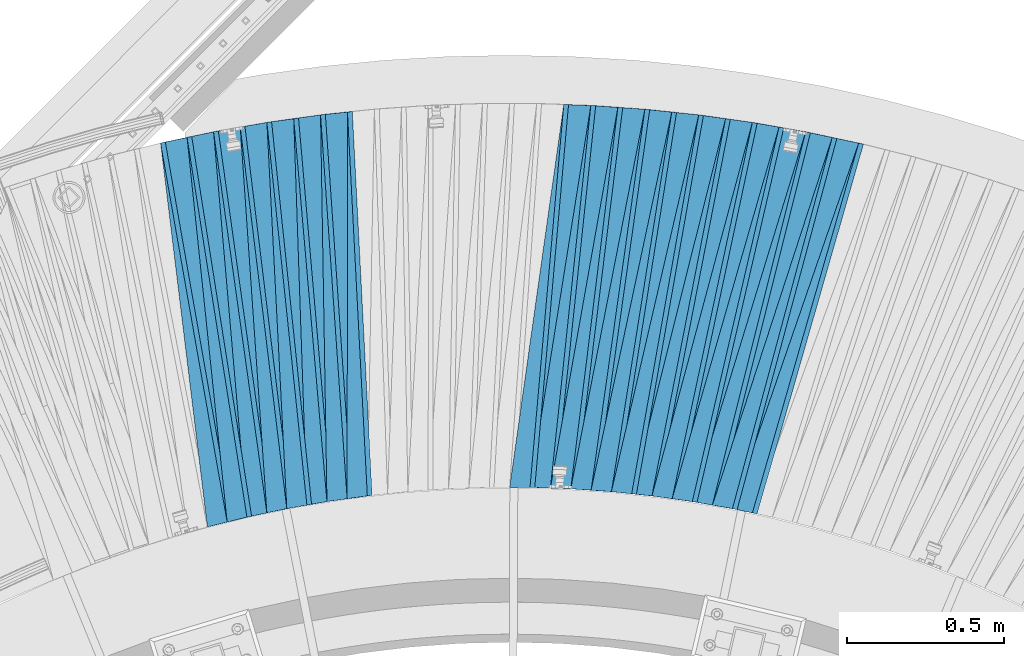
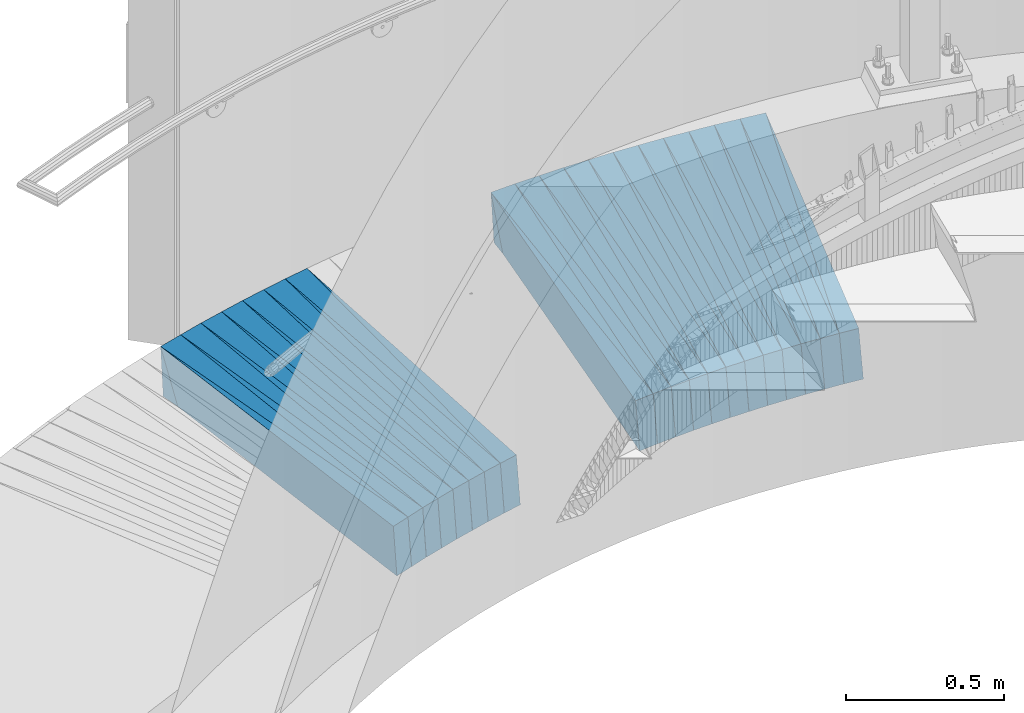
# One storey, part 838 of 975: 38 plates.
"""IFC2X3 building model written with IfcOpenShell, lengths in millimetres."""

from ifc_helpers import new_model, si_unit, frame, origin_with_axes, place, context, subcontext, project, spatial, faceted_brep, material, type_object, element, save


model = new_model("IFC2X3")

# Units and contexts
model_context = context("Model", 3, precision=1e-05, world=origin_with_axes())
body_context = subcontext(model_context, "Body", "Model", "MODEL_VIEW")
ifc_project = project(units=[si_unit("LENGTHUNIT", "METRE", prefix="MILLI"), si_unit("AREAUNIT", "SQUARE_METRE"), si_unit("VOLUMEUNIT", "CUBIC_METRE"), si_unit("MASSUNIT", "GRAM", prefix="KILO"), si_unit("TIMEUNIT", "SECOND"), si_unit("PLANEANGLEUNIT", "RADIAN"), si_unit("SOLIDANGLEUNIT", "STERADIAN"), si_unit("THERMODYNAMICTEMPERATUREUNIT", "DEGREE_CELSIUS"), si_unit("LUMINOUSINTENSITYUNIT", "LUMEN")], contexts=[model_context])

# Site, building, storey
site_placement = place(None, origin_with_axes())
site = spatial("IfcSite", under=ifc_project, at=site_placement, CompositionType="ELEMENT")
building_placement = place(site_placement, origin_with_axes())
building = spatial("IfcBuilding", under=site, at=building_placement, Name="Undefined", CompositionType="ELEMENT")
storey_placement = place(building_placement, origin_with_axes())
storey = spatial("IfcBuildingStorey", under=building, at=storey_placement, Name="Undefined", CompositionType="ELEMENT", Elevation=0.0)

# Plates
ifc_material = material(Name="STEEL/A36")
plate_type_1 = type_object("IfcPlateType", PredefinedType="NOTDEFINED")
plate_1_placement = place(storey_placement, frame((35764.605502556, 8221.70274465771, 73.7905738008885), z_axis=(0.964055581401103, -0.259311554563337, 0.057916782018052), x_axis=(-0.259515912954683, -0.965730145831356, -0.00409589499928474)))
element("IfcPlate", 1, at=plate_1_placement, inside=storey, type_object=plate_type_1, material=ifc_material, Name="SLAB", context=body_context, shape_type="Brep", body=[
    faceted_brep([(-6.82121026329696e-12, -100.000000000011, -1.09139364212751e-10), (-4.55919837962938, -99.9999999999691, 86.0083389287502), (-4.559198379382, 99.9999999999982, 86.0083389282008), (5.91171556152403e-12, 100.000000000011, 1.09139364212751e-10), (1220.73437500095, -100.00000000007, -6.584741640836e-10), (1220.7343750012, 99.9999999998965, -1.21508492156863e-09)], [[[0, 1, 2, 3]], [[1, 4, 5, 2]], [[4, 0, 3, 5]], [[5, 3, 2]], [[4, 1, 0]]]),
])
plate_2_placement = place(storey_placement, frame((35680.4185467574, 8239.69587528962, 68.7903290060016), z_axis=(0.968478990564453, -0.242277277368658, 0.0578806159788259), x_axis=(-0.242456660088825, -0.970153952355419, -0.00400957700146893)))
element("IfcPlate", 2, at=plate_2_placement, inside=storey, type_object=plate_type_1, material=ifc_material, Name="SLAB", context=body_context, shape_type="Brep", body=[
    faceted_brep([(-6.82121026329696e-12, -100.000000000011, -1.09139364212751e-10), (-3.06914281841091, -100.000000000004, 86.1720962523905), (-3.06914281867284, 100.000000000015, 86.1720962527033), (5.91171556152403e-12, 100.000000000011, 1.09139364212751e-10), (1222.07409668038, -100.000000000044, -5.56610757485032e-10), (1222.07409668012, 99.9999999999743, -2.47382558882236e-10)], [[[0, 1, 2, 3]], [[1, 4, 5, 2]], [[4, 0, 3, 5]], [[5, 3, 2]], [[4, 1, 0]]]),
])
plate_3_placement = place(storey_placement, frame((35595.6267236072, 8254.72910454201, 63.8838515331064), z_axis=(0.972598820152964, -0.225458207081955, 0.0567462060093355), x_axis=(-0.225593408988377, -0.974212932949807, -0.00409574099978898)))
element("IfcPlate", 3, at=plate_3_placement, inside=storey, type_object=plate_type_1, material=ifc_material, Name="SLAB", context=body_context, shape_type="Brep", body=[
    faceted_brep([(-6.82121026329696e-12, -100.000000000011, -1.09139364212751e-10), (-4.61205816275833, -99.9999999999795, 86.0165023807131), (-4.61205816267102, 99.999999999987, 86.0165023801528), (5.91171556152403e-12, 100.000000000011, 1.09139364212751e-10), (1220.7803955086, -100.000000000214, -3.77258402295411e-09), (1220.78039550869, 99.9999999997531, -4.33647073805332e-09)], [[[0, 1, 2, 3]], [[1, 4, 5, 2]], [[4, 0, 3, 5]], [[5, 3, 2]], [[4, 1, 0]]]),
])
plate_4_placement = place(storey_placement, frame((35511.0556919054, 8269.6944571652, 58.8906398262733), z_axis=(0.976331071088854, -0.2083777056512, 0.0579341990022646), x_axis=(-0.208499042945997, -0.978014351746696, -0.00400959699896152)))
element("IfcPlate", 4, at=plate_4_placement, inside=storey, type_object=plate_type_1, material=ifc_material, Name="SLAB", context=body_context, shape_type="Brep", body=[
    faceted_brep([(-6.82121026329696e-12, -100.000000000011, -1.09139364212751e-10), (-3.10750317586462, -99.9999999999727, 86.0897369389422), (-3.10750317581915, 99.9999999999966, 86.0897369383965), (5.91171556152403e-12, 100.000000000011, 1.09139364212751e-10), (1222.06799316404, -99.9999999997672, 4.69299266114831e-09), (1222.06799316408, 100.000000000202, 4.16184775531292e-09)], [[[0, 1, 2, 3]], [[1, 4, 5, 2]], [[4, 0, 3, 5]], [[5, 3, 2]], [[4, 1, 0]]]),
])
plate_5_placement = place(storey_placement, frame((35425.8579234587, 8281.82470681886, 53.9840768629625), z_axis=(0.979861523169143, -0.191433444205892, 0.0567858420041172), x_axis=(-0.19151260201159, -0.981481609059398, -0.00409565000024787)))
element("IfcPlate", 5, at=plate_5_placement, inside=storey, type_object=plate_type_1, material=ifc_material, Name="SLAB", context=body_context, shape_type="Brep", body=[
    faceted_brep([(-6.82121026329696e-12, -100.000000000011, -1.09139364212751e-10), (-4.54001188280381, -99.9999999999804, 85.961669922217), (-4.54001188273469, 99.9999999999905, 85.9616699217149), (5.91171556152403e-12, 100.000000000011, 1.09139364212751e-10), (1220.80737304752, -99.9999999998954, 1.78260961547494e-09), (1220.80737304759, 100.000000000075, 1.28056854009628e-09)], [[[0, 1, 2, 3]], [[1, 4, 5, 2]], [[4, 0, 3, 5]], [[5, 3, 2]], [[4, 1, 0]]]),
])
plate_6_placement = place(storey_placement, frame((35340.7792414724, 8293.90386042257, 48.9905059479369), z_axis=(0.983000901638346, -0.174230280495049, 0.057905411982096), x_axis=(-0.174287989057401, -0.984686223324289, -0.00409126700134739)))
element("IfcPlate", 6, at=plate_6_placement, inside=storey, type_object=plate_type_1, material=ifc_material, Name="SLAB", context=body_context, shape_type="Brep", body=[
    faceted_brep([(-6.82121026329696e-12, -100.000000000011, -1.09139364212751e-10), (-3.05355834965485, -100.00000000002, 86.1319656368723), (-3.05355834966576, 100.000000000004, 86.131965637258), (5.91171556152403e-12, 100.000000000011, 1.09139364212751e-10), (1222.11523437546, -100.000000000117, -2.35013430938125e-09), (1222.11523437545, 99.9999999999063, -1.96450855582952e-09)], [[[0, 1, 2, 3]], [[1, 4, 5, 2]], [[4, 0, 3, 5]], [[5, 3, 2]], [[4, 1, 0]]]),
])
plate_7_placement = place(storey_placement, frame((35255.2900291314, 8302.99648943306, 43.9906100897005), z_axis=(0.985885321670632, -0.157080835764449, 0.0579287799797034), x_axis=(-0.157113782975789, -0.987572350847801, -0.00401385599938141)))
element("IfcPlate", 7, at=plate_7_placement, inside=storey, type_object=plate_type_1, material=ifc_material, Name="SLAB", context=body_context, shape_type="Brep", body=[
    faceted_brep([(-6.82121026329696e-12, -100.000000000011, -1.09139364212751e-10), (-4.56514644626259, -99.9999999999941, 85.9965667725555), (-4.5651464461971, 100.000000000007, 85.9965667725774), (5.91171556152403e-12, 100.000000000011, 1.09139364212751e-10), (1220.77136230519, -99.9999999998824, 1.90630089491606e-09), (1220.77136230525, 100.000000000118, 1.92812876775861e-09)], [[[0, 1, 2, 3]], [[1, 4, 5, 2]], [[4, 0, 3, 5]], [[5, 3, 2]], [[4, 1, 0]]]),
])
plate_8_placement = place(storey_placement, frame((35169.6864097936, 8312.01339526982, 39.0841267151234), z_axis=(0.988553321968879, -0.139771264818067, 0.0568007319975048), x_axis=(-0.139770274969739, -0.990175838785613, -0.00400980299913182)))
element("IfcPlate", 8, at=plate_8_placement, inside=storey, type_object=plate_type_1, material=ifc_material, Name="SLAB", context=body_context, shape_type="Brep", body=[
    faceted_brep([(-6.82121026329696e-12, -100.000000000011, -1.09139364212751e-10), (-3.15744161615476, -100.000000000003, 86.0435943603006), (-3.15744161608018, 100.000000000025, 86.0435943607881), (5.91171556152403e-12, 100.000000000011, 1.09139364212751e-10), (1222.00512695307, -99.9999999998477, 2.05909600481391e-09), (1222.00512695315, 100.00000000018, 2.55386112257838e-09)], [[[0, 1, 2, 3]], [[1, 4, 5, 2]], [[4, 0, 3, 5]], [[5, 3, 2]], [[4, 1, 0]]]),
])
plate_9_placement = place(storey_placement, frame((35083.8875538046, 8318.12138796366, 34.1838202332682), z_axis=(0.990834619860875, -0.122585688774441, 0.0567406819914285), x_axis=(-0.12255144400627, -0.992453710050773, -0.00409597100020955)))
element("IfcPlate", 9, at=plate_9_placement, inside=storey, type_object=plate_type_1, material=ifc_material, Name="SLAB", context=body_context, shape_type="Brep", body=[
    faceted_brep([(-6.82121026329696e-12, -100.000000000011, -1.09139364212751e-10), (-4.58026170729863, -99.9999999999757, 86.027153015566), (-4.58026170745325, 100.000000000013, 86.0271530153477), (5.91171556152403e-12, 100.000000000011, 1.09139364212751e-10), (1220.71179199231, -100.000000000141, -1.84809323400259e-09), (1220.71179199215, 99.9999999998465, -2.05909600481391e-09)], [[[0, 1, 2, 3]], [[1, 4, 5, 2]], [[4, 0, 3, 5]], [[5, 3, 2]], [[4, 1, 0]]]),
])
plate_10_placement = place(storey_placement, frame((34998.2095757124, 8324.20800457314, 29.1906252965995), z_axis=(0.992761712832039, -0.105208186985022, 0.0579259779902053), x_axis=(-0.1051481829612, -0.994448148633038, -0.00409136899849024)))
element("IfcPlate", 10, at=plate_10_placement, inside=storey, type_object=plate_type_1, material=ifc_material, Name="SLAB", context=body_context, shape_type="Brep", body=[
    faceted_brep([(-6.82121026329696e-12, -100.000000000011, -1.09139364212751e-10), (-3.07548213005975, -99.9999999999691, 86.0998306279726), (-3.07548212996699, 99.9999999999923, 86.0998306273177), (5.91171556152403e-12, 100.000000000011, 1.09139364212751e-10), (1222.08483886739, -99.9999999998463, 3.08500602841377e-09), (1222.0848388674, 100.000000000158, 3.09955794364214e-09)], [[[0, 1, 2, 3]], [[1, 4, 5, 2]], [[4, 0, 3, 5]], [[5, 3, 2]], [[4, 1, 0]]]),
])
plate_11_placement = place(storey_placement, frame((34912.2067349827, 8327.31002952668, 24.1903049663771), z_axis=(0.994446331117044, -0.0879062493161221, 0.0578704230071204), x_axis=(-0.0878165689614517, -0.996128241562713, -0.00409592199820195)))
element("IfcPlate", 11, at=plate_11_placement, inside=storey, type_object=plate_type_1, material=ifc_material, Name="SLAB", context=body_context, shape_type="Brep", body=[
    faceted_brep([(-6.82121026329696e-12, -100.000000000011, -1.09139364212751e-10), (-4.58431959140762, -100.000000000004, 86.0754547118559), (-4.58431959155314, 100.000000000022, 86.0754547122851), (5.91171556152403e-12, 100.000000000011, 1.09139364212751e-10), (1220.7263183595, -100.000000000236, -4.8748916015029e-09), (1220.72631835935, 99.9999999997897, -4.43833414465189e-09)], [[[0, 1, 2, 3]], [[1, 4, 5, 2]], [[4, 0, 3, 5]], [[5, 3, 2]], [[4, 1, 0]]]),
])
plate_12_placement = place(storey_placement, frame((34139.759102008, 8295.31905065966, -20.4092313566496), z_axis=(0.99594667004959, 0.0687891565701411, 0.0579506889993781), x_axis=(0.069141298985726, -0.997598487794038, -0.00409120099915534)))
element("IfcPlate", 12, at=plate_12_placement, inside=storey, type_object=plate_type_1, material=ifc_material, Name="SLAB", context=body_context, shape_type="Brep", body=[
    faceted_brep([(-6.82121026329696e-12, -100.000000000011, -1.09139364212751e-10), (-3.08726119992662, -99.9999999999977, 86.0622940063986), (-3.087261199973, 100.000000000032, 86.0622940069079), (5.91171556152403e-12, 100.000000000011, 1.09139364212751e-10), (1222.13500976625, -100.000000000171, -3.47063178196549e-09), (1222.1350097662, 99.9999999998595, -2.95403879135847e-09)], [[[0, 1, 2, 3]], [[1, 4, 5, 2]], [[4, 0, 3, 5]], [[5, 3, 2]], [[4, 1, 0]]]),
])
plate_13_placement = place(storey_placement, frame((34054.5368614062, 8283.41892436918, -25.4096521035713), z_axis=(0.994602079277499, 0.0861211889418626, 0.0578778430154009), x_axis=(0.0865016370427408, -0.99624328949228, -0.00409572100202385)))
element("IfcPlate", 13, at=plate_13_placement, inside=storey, type_object=plate_type_1, material=ifc_material, Name="SLAB", context=body_context, shape_type="Brep", body=[
    faceted_brep([(-6.82121026329696e-12, -100.000000000011, -1.09139364212751e-10), (-4.60545873652791, -99.999999999987, 86.0629425050938), (-4.60545873638694, 99.9999999999895, 86.0629425047009), (5.91171556152403e-12, 100.000000000011, 1.09139364212751e-10), (1220.78613281197, -99.9999999998649, 2.62662069872022e-09), (1220.78613281211, 100.000000000112, 2.2409949451685e-09)], [[[0, 1, 2, 3]], [[1, 4, 5, 2]], [[4, 0, 3, 5]], [[5, 3, 2]], [[4, 1, 0]]]),
])
plate_14_placement = place(storey_placement, frame((33969.3226987477, 8271.5194156429, -30.4094995051612), z_axis=(0.992932359180917, 0.103597318001857, 0.0579044540103788), x_axis=(0.104006596044437, -0.994568191424915, -0.00409152600174805)))
element("IfcPlate", 14, at=plate_14_placement, inside=storey, type_object=plate_type_1, material=ifc_material, Name="SLAB", context=body_context, shape_type="Brep", body=[
    faceted_brep([(-6.82121026329696e-12, -100.000000000011, -1.09139364212751e-10), (-3.09391403193695, -99.9999999999914, 86.1305236817861), (-3.09391403215795, 99.9999999999695, 86.1305236810949), (5.91171556152403e-12, 100.000000000011, 1.09139364212751e-10), (1222.03784179759, -99.9999999997447, 5.17320586368442e-09), (1222.03784179737, 100.000000000216, 4.48926584795117e-09)], [[[0, 1, 2, 3]], [[1, 4, 5, 2]], [[4, 0, 3, 5]], [[5, 3, 2]], [[4, 1, 0]]]),
])
plate_15_placement = place(storey_placement, frame((33884.7124940008, 8256.71114013125, -35.4091145866803), z_axis=(0.990991434238703, 0.120725880859667, 0.0579761930120975), x_axis=(0.121159712948324, -0.992624909576633, -0.00401408099828794)))
element("IfcPlate", 15, at=plate_15_placement, inside=storey, type_object=plate_type_1, material=ifc_material, Name="SLAB", context=body_context, shape_type="Brep", body=[
    faceted_brep([(-6.82121026329696e-12, -100.000000000011, -1.09139364212751e-10), (-4.56007003787408, -100.000000000015, 85.9265747067693), (-4.56007003778313, 99.9999999999768, 85.9265747066311), (5.91171556152403e-12, 100.000000000011, 1.09139364212751e-10), (1220.70275878989, -99.9999999997904, 3.18686943501234e-09), (1220.70275878998, 100.000000000202, 3.06317815557122e-09)], [[[0, 1, 2, 3]], [[1, 4, 5, 2]], [[4, 0, 3, 5]], [[5, 3, 2]], [[4, 1, 0]]]),
])
plate_16_placement = place(storey_placement, frame((33799.8737275223, 8241.89392777915, -40.3160031597552), z_axis=(0.988791594099933, 0.138084942108144, 0.0567779200068544), x_axis=(0.138532769005874, -0.990349734042003, -0.00400951300017006)))
element("IfcPlate", 16, at=plate_16_placement, inside=storey, type_object=plate_type_1, material=ifc_material, Name="SLAB", context=body_context, shape_type="Brep", body=[
    faceted_brep([(-6.82121026329696e-12, -100.000000000011, -1.09139364212751e-10), (-3.04213213912999, -99.9999999999995, 86.0863265991284), (-3.04213213918047, 99.9999999999973, 86.0863265990847), (5.91171556152403e-12, 100.000000000011, 1.09139364212751e-10), (1222.09350585966, -99.999999999872, 3.60887497663498e-09), (1222.09350585961, 100.000000000125, 3.56521923094988e-09)], [[[0, 1, 2, 3]], [[1, 4, 5, 2]], [[4, 0, 3, 5]], [[5, 3, 2]], [[4, 1, 0]]]),
])
plate_17_placement = place(storey_placement, frame((33715.6425197186, 8224.09809821937, -45.216449938061), z_axis=(0.986236292747657, 0.155318581026175, 0.0566931499863439), x_axis=(0.15579721704757, -0.987780569301605, -0.00409561600125054)))
element("IfcPlate", 17, at=plate_17_placement, inside=storey, type_object=plate_type_1, material=ifc_material, Name="SLAB", context=body_context, shape_type="Brep", body=[
    faceted_brep([(-6.82121026329696e-12, -100.000000000011, -1.09139364212751e-10), (-4.58321523664108, -99.9999999999948, 86.0990982056683), (-4.58321523675841, 99.9999999999702, 86.0990982050353), (5.91171556152403e-12, 100.000000000011, 1.09139364212751e-10), (1220.81774902334, -99.9999999999127, 3.78349795937538e-10), (1220.81774902322, 100.000000000053, -2.5465851649642e-10)], [[[0, 1, 2, 3]], [[1, 4, 5, 2]], [[4, 0, 3, 5]], [[5, 3, 2]], [[4, 1, 0]]]),
])
plate_18_placement = place(storey_placement, frame((33631.6440143375, 8206.30793033107, -50.2092933695438), z_axis=(0.983297056879705, 0.172537504394019, 0.0579457289987202), x_axis=(0.173055720005732, -0.984903875032618, -0.00400932900013278)))
element("IfcPlate", 18, at=plate_18_placement, inside=storey, type_object=plate_type_1, material=ifc_material, Name="SLAB", context=body_context, shape_type="Brep", body=[
    faceted_brep([(-6.82121026329696e-12, -100.000000000011, -1.09139364212751e-10), (-3.09583997723848, -99.9999999999879, 86.073432922567), (-3.09583997711343, 100.000000000011, 86.073432922567), (5.91171556152403e-12, 100.000000000011, 1.09139364212751e-10), (1222.14978027348, -99.9999999999643, 2.69210431724787e-10), (1222.1497802736, 100.000000000035, 2.7648638933897e-10)], [[[0, 1, 2, 3]], [[1, 4, 5, 2]], [[4, 0, 3, 5]], [[5, 3, 2]], [[4, 1, 0]]]),
])
plate_type_2 = type_object("IfcPlateType", PredefinedType="NOTDEFINED")
plate_19_placement = place(storey_placement, frame((35850.5119113249, 8203.17787494596, 78.9190200785627), z_axis=(0.942252558940146, -0.3260250351283, 0.0766015119977239), x_axis=(-0.326383799059595, -0.945202272172581, -0.00814127700148648)))
element("IfcPlate", 19, at=plate_19_placement, inside=storey, type_object=plate_type_2, material=ifc_material, Name="SLAB", context=body_context, shape_type="Brep", body=[
    faceted_brep([(-6.82121026329696e-12, -100.000000000011, -1.09139364212751e-10), (1220.36791992194, -100.000000000029, 64.4289321896067), (1220.36791992196, 99.9999999999741, 64.4289321896467), (5.91171556152403e-12, 100.000000000011, 1.09139364212751e-10), (1228.30847167972, -100.000000000028, -1.93540472537279e-09), (1228.30847167975, 99.999999999975, -1.89902493730187e-09)], [[[0, 1, 2, 3]], [[1, 4, 5, 2]], [[4, 0, 3, 5]], [[5, 3, 2]], [[4, 1, 0]]]),
])
plate_20_placement = place(storey_placement, frame((35682.2607297798, 8239.2349549028, 68.9185700473539), z_axis=(0.953078958781384, -0.29288282840706, 0.0765515979746576), x_axis=(-0.293143726972705, -0.956034415910989, -0.00805921399924965)))
element("IfcPlate", 20, at=plate_20_placement, inside=storey, type_object=plate_type_2, material=ifc_material, Name="SLAB", context=body_context, shape_type="Brep", body=[
    faceted_brep([(-6.82121026329696e-12, -100.000000000011, -1.09139364212751e-10), (1220.37243652325, -99.9999999999977, 64.4694824219368), (1220.3724365233, 99.9999999999923, 64.4694824218095), (5.91171556152403e-12, 100.000000000011, 1.09139364212751e-10), (1228.40771484352, -99.9999999999945, -3.27418092638254e-10), (1228.40771484356, 99.999999999995, -4.54747350886464e-10)], [[[0, 1, 2, 3]], [[1, 4, 5, 2]], [[4, 0, 3, 5]], [[5, 3, 2]], [[4, 1, 0]]]),
])
plate_21_placement = place(storey_placement, frame((35512.9129287261, 8269.29799392248, 59.018991973222), z_axis=(0.962711705406642, -0.259456387254315, 0.0766064970219533), x_axis=(-0.259614670981735, -0.965678655932064, -0.00805953399943301)))
element("IfcPlate", 21, at=plate_21_placement, inside=storey, type_object=plate_type_2, material=ifc_material, Name="SLAB", context=body_context, shape_type="Brep", body=[
    faceted_brep([(-6.82121026329696e-12, -100.000000000011, -1.09139364212751e-10), (1220.36840820335, -100.000000000219, 64.4279632539692), (1220.36840820337, 99.9999999997931, 64.4279632541329), (5.91171556152403e-12, 100.000000000011, 1.09139364212751e-10), (1228.35888671898, -100.000000000207, -2.08092387765646e-09), (1228.35888671901, 99.9999999998045, -1.91357685253024e-09)], [[[0, 1, 2, 3]], [[1, 4, 5, 2]], [[4, 0, 3, 5]], [[5, 3, 2]], [[4, 1, 0]]]),
])
plate_22_placement = place(storey_placement, frame((35427.8337766105, 8281.43860353971, 54.1189733335936), z_axis=(0.967073963605498, -0.242695492112916, 0.0765953459710329), x_axis=(-0.242795784909989, -0.970043253640377, -0.00814204499698151)))
element("IfcPlate", 22, at=plate_22_placement, inside=storey, type_object=plate_type_2, material=ifc_material, Name="SLAB", context=body_context, shape_type="Brep", body=[
    faceted_brep([(-6.82121026329696e-12, -100.000000000011, -1.09139364212751e-10), (1219.11218261705, -99.9999999997185, 64.3128662146046), (1219.1121826169, 100.000000000332, 64.3128662152558), (5.91171556152403e-12, 100.000000000011, 1.09139364212751e-10), (1228.19262695305, -99.9999999997171, 4.58021531812847e-09), (1228.19262695289, 100.000000000333, 5.23141352459788e-09)], [[[0, 1, 2, 3]], [[1, 4, 5, 2]], [[4, 0, 3, 5]], [[5, 3, 2]], [[4, 1, 0]]]),
])
plate_23_placement = place(storey_placement, frame((35342.508214564, 8293.59734715231, 49.1078660835137), z_axis=(0.971292333788656, -0.22570892054748, 0.0751444309891155), x_axis=(-0.225749904975231, -0.974151950893104, -0.00805958899911561)))
element("IfcPlate", 23, at=plate_23_placement, inside=storey, type_object=plate_type_2, material=ifc_material, Name="SLAB", context=body_context, shape_type="Brep", body=[
    faceted_brep([(-6.82121026329696e-12, -100.000000000011, -1.09139364212751e-10), (1220.41943359372, -99.999999999899, 64.3571243299193), (1220.41943359373, 100.000000000155, 64.3571243306396), (5.91171556152403e-12, 100.000000000011, 1.09139364212751e-10), (1228.35046386717, -99.9999999998877, 2.3283064365387e-10), (1228.35046386718, 100.000000000166, 9.53150447458029e-10)], [[[0, 1, 2, 3]], [[1, 4, 5, 2]], [[4, 0, 3, 5]], [[5, 3, 2]], [[4, 1, 0]]]),
])
plate_24_placement = place(storey_placement, frame((35171.6757641942, 8311.73203879611, 39.2187392565894), z_axis=(0.978462847858353, -0.191694925611359, 0.0765735649932661), x_axis=(-0.191645688012599, -0.981431082064528, -0.00805986500052993)))
element("IfcPlate", 24, at=plate_24_placement, inside=storey, type_object=plate_type_2, material=ifc_material, Name="SLAB", context=body_context, shape_type="Brep", body=[
    faceted_brep([(-6.82121026329696e-12, -100.000000000011, -1.09139364212751e-10), (1220.30419921816, -100.000000000085, 64.4541931140193), (1220.30419921823, 99.9999999999177, 64.4541931140629), (5.91171556152403e-12, 100.000000000011, 1.09139364212751e-10), (1228.30834960875, -100.00000000009, -1.80443748831749e-09), (1228.30834960883, 99.9999999999122, -1.76078174263239e-09)], [[[0, 1, 2, 3]], [[1, 4, 5, 2]], [[4, 0, 3, 5]], [[5, 3, 2]], [[4, 1, 0]]]),
])
plate_25_placement = place(storey_placement, frame((35000.0967918447, 8324.00793178634, 29.3188622100358), z_axis=(0.984553814007914, -0.15744567773302, 0.0765809760035732), x_axis=(-0.157286689056187, -0.987519427352785, -0.00814113300290837)))
element("IfcPlate", 25, at=plate_25_placement, inside=storey, type_object=plate_type_2, material=ifc_material, Name="SLAB", context=body_context, shape_type="Brep", body=[
    faceted_brep([(-6.82121026329696e-12, -100.000000000011, -1.09139364212751e-10), (1220.38439941511, -100.000000000022, 64.4456634519738), (1220.38439941509, 99.9999999999645, 64.4456634517992), (5.91171556152403e-12, 100.000000000011, 1.09139364212751e-10), (1228.3303222667, -100.000000000018, -2.40106601268053e-10), (1228.33032226668, 99.9999999999686, -4.07453626394272e-10)], [[[0, 1, 2, 3]], [[1, 4, 5, 2]], [[4, 0, 3, 5]], [[5, 3, 2]], [[4, 1, 0]]]),
])
plate_26_placement = place(storey_placement, frame((34141.6514219088, 8295.44967728745, -20.2810219608469), z_axis=(0.996934856286814, 0.0159351166474935, 0.0765961120280901), x_axis=(0.0166068320036651, -0.999828957220828, -0.00814060400179798)))
element("IfcPlate", 26, at=plate_26_placement, inside=storey, type_object=plate_type_2, material=ifc_material, Name="SLAB", context=body_context, shape_type="Brep", body=[
    faceted_brep([(-6.82121026329696e-12, -100.000000000011, -1.09139364212751e-10), (1220.43542480526, -100.000000000065, 64.4299240104301), (1220.4354248053, 99.9999999999745, 64.429924010954), (5.91171556152403e-12, 100.000000000011, 1.09139364212751e-10), (1228.41015625058, -100.000000000072, -1.5352270565927e-09), (1228.41015625062, 99.9999999999682, -1.00408215075731e-09)], [[[0, 1, 2, 3]], [[1, 4, 5, 2]], [[4, 0, 3, 5]], [[5, 3, 2]], [[4, 1, 0]]]),
])
plate_27_placement = place(storey_placement, frame((33971.0556864283, 8271.7001635962, -30.2931651609586), z_axis=(0.995888756903831, 0.050788508731999, 0.0750074079896188), x_axis=(0.0515358099916105, -0.998638620837467, -0.00806010299868819)))
element("IfcPlate", 27, at=plate_27_placement, inside=storey, type_object=plate_type_2, material=ifc_material, Name="SLAB", context=body_context, shape_type="Brep", body=[
    faceted_brep([(-6.82121026329696e-12, -100.000000000011, -1.09139364212751e-10), (1220.33593749919, -99.9999999997199, 64.4740676916263), (1220.33593749903, 100.000000000275, 64.4740676915535), (5.91171556152403e-12, 100.000000000011, 1.09139364212751e-10), (1228.27209472574, -99.999999999704, 3.71801434084773e-09), (1228.27209472558, 100.000000000291, 3.63797880709171e-09)], [[[0, 1, 2, 3]], [[1, 4, 5, 2]], [[4, 0, 3, 5]], [[5, 3, 2]], [[4, 1, 0]]]),
])
plate_28_placement = place(storey_placement, frame((33801.8697804081, 8242.17259423601, -40.1809540116154), z_axis=(0.993394772198545, 0.085423575803843, 0.0766135710268467), x_axis=(0.0862895700130673, -0.99623750215085, -0.00805912000122031)))
element("IfcPlate", 28, at=plate_28_placement, inside=storey, type_object=plate_type_2, material=ifc_material, Name="SLAB", context=body_context, shape_type="Brep", body=[
    faceted_brep([(-6.82121026329696e-12, -100.000000000011, -1.09139364212751e-10), (1220.39453125059, -100.000000000116, 64.4181747421972), (1220.39453125067, 99.999999999935, 64.4181747428738), (5.91171556152403e-12, 100.000000000011, 1.09139364212751e-10), (1228.42187500054, -100.000000000133, -1.71712599694729e-09), (1228.42187500062, 99.9999999999181, -1.04773789644241e-09)], [[[0, 1, 2, 3]], [[1, 4, 5, 2]], [[4, 0, 3, 5]], [[5, 3, 2]], [[4, 1, 0]]]),
])
plate_29_placement = place(storey_placement, frame((33633.5156159512, 8206.63626321406, -50.0808342030895), z_axis=(0.989801267511988, 0.120089248387306, 0.0766291279699453), x_axis=(0.121054357045533, -0.992613161373355, -0.00805943600303142)))
element("IfcPlate", 29, at=plate_29_placement, inside=storey, type_object=plate_type_2, material=ifc_material, Name="SLAB", context=body_context, shape_type="Brep", body=[
    faceted_brep([(-6.82121026329696e-12, -100.000000000011, -1.09139364212751e-10), (1220.4509277354, -99.9999999997035, 64.4160537759599), (1220.45092773547, 100.000000000255, 64.4160537754215), (5.91171556152403e-12, 100.000000000011, 1.09139364212751e-10), (1228.37377929787, -99.9999999996971, 4.79485606774688e-09), (1228.37377929794, 100.000000000261, 4.2564352042973e-09)], [[[0, 1, 2, 3]], [[1, 4, 5, 2]], [[4, 0, 3, 5]], [[5, 3, 2]], [[4, 1, 0]]]),
])
plate_type_3 = type_object("IfcPlateType", PredefinedType="NOTDEFINED")
plate_30_placement = place(storey_placement, frame((35766.3013381842, 8221.24653318741, 73.9079688859877), z_axis=(0.947917965809429, -0.309520295864185, 0.0751579439837355), x_axis=(-0.309810530907454, -0.950764144715987, -0.00806077299759208)))
element("IfcPlate", 30, at=plate_30_placement, inside=storey, type_object=plate_type_3, material=ifc_material, Name="SLAB", context=body_context, shape_type="Brep", body=[
    faceted_brep([(-6.82121026329696e-12, -100.000000000011, -1.09139364212751e-10), (1219.04418945479, -100.000000000311, 64.217277522861), (1219.04418945476, 99.999999999694, 64.2172775229155), (5.91171556152403e-12, 100.000000000011, 1.09139364212751e-10), (1228.17004394692, -100.000000000308, -1.70621206052601e-09), (1228.1700439469, 99.9999999996971, -1.66255631484091e-09)], [[[0, 1, 2, 3]], [[1, 4, 5, 2]], [[4, 0, 3, 5]], [[5, 3, 2]], [[4, 1, 0]]]),
])
plate_31_placement = place(storey_placement, frame((35597.4455454985, 8254.30740957835, 64.0075057639823), z_axis=(0.95815267972445, -0.276231712386705, 0.075096493984497), x_axis=(-0.276421592975933, -0.961002668916325, -0.00806059999929816)))
element("IfcPlate", 31, at=plate_31_placement, inside=storey, type_object=plate_type_3, material=ifc_material, Name="SLAB", context=body_context, shape_type="Brep", body=[
    faceted_brep([(-6.82121026329696e-12, -100.000000000011, -1.09139364212751e-10), (1219.08728027489, -100.000000000174, 64.2716445901569), (1219.08728027511, 99.9999999997835, 64.2716445896076), (5.91171556152403e-12, 100.000000000011, 1.09139364212751e-10), (1228.19641113429, -100.000000000185, -2.16823536902666e-09), (1228.19641113451, 99.9999999997726, -2.7212081477046e-09)], [[[0, 1, 2, 3]], [[1, 4, 5, 2]], [[4, 0, 3, 5]], [[5, 3, 2]], [[4, 1, 0]]]),
])
plate_32_placement = place(storey_placement, frame((35257.0260513541, 8302.71982630221, 44.1081627425714), z_axis=(0.97508797015605, -0.208685314902629, 0.0751923520109962), x_axis=(-0.208682709083387, -0.977950846390766, -0.00797928400318833)))
element("IfcPlate", 32, at=plate_32_placement, inside=storey, type_object=plate_type_3, material=ifc_material, Name="SLAB", context=body_context, shape_type="Brep", body=[
    faceted_brep([(-6.82121026329696e-12, -100.000000000011, -1.09139364212751e-10), (1219.0820312497, -99.9999999999086, 64.2006988536668), (1219.08203124992, 100.000000000053, 64.200698853183), (5.91171556152403e-12, 100.000000000011, 1.09139364212751e-10), (1228.1802978512, -99.9999999998954, 2.71029421128333e-09), (1228.18029785141, 100.000000000066, 2.22644302994013e-09)], [[[0, 1, 2, 3]], [[1, 4, 5, 2]], [[4, 0, 3, 5]], [[5, 3, 2]], [[4, 1, 0]]]),
])
plate_33_placement = place(storey_placement, frame((35085.8928084871, 8317.87321383893, 34.3191905459753), z_axis=(0.981654845575646, -0.17459263161284, 0.0766236069651959), x_axis=(-0.174485542962386, -0.984626071787759, -0.00814211599824492)))
element("IfcPlate", 33, at=plate_33_placement, inside=storey, type_object=plate_type_3, material=ifc_material, Name="SLAB", context=body_context, shape_type="Brep", body=[
    faceted_brep([(-6.82121026329696e-12, -100.000000000011, -1.09139364212751e-10), (1219.01818847685, -100.000000000136, 64.2802886945137), (1219.01818847687, 99.9999999998181, 64.2802886939171), (5.91171556152403e-12, 100.000000000011, 1.09139364212751e-10), (1228.18200683628, -100.00000000015, -2.64844857156277e-09), (1228.18200683629, 99.999999999804, -3.25235305353999e-09)], [[[0, 1, 2, 3]], [[1, 4, 5, 2]], [[4, 0, 3, 5]], [[5, 3, 2]], [[4, 1, 0]]]),
])
plate_34_placement = place(storey_placement, frame((34913.9578578065, 8327.15517128327, 24.3077564124241), z_axis=(0.987271896269856, -0.14017748644017, 0.0751297220215664), x_axis=(-0.13996888104867, -0.990123089344283, -0.00806103500280296)))
element("IfcPlate", 34, at=plate_34_placement, inside=storey, type_object=plate_type_3, material=ifc_material, Name="SLAB", context=body_context, shape_type="Brep", body=[
    faceted_brep([(-6.82121026329696e-12, -100.000000000011, -1.09139364212751e-10), (1219.03466796939, -100.000000000013, 64.244628906119), (1219.03466796921, 100.000000000014, 64.2446289064537), (5.91171556152403e-12, 100.000000000011, 1.09139364212751e-10), (1228.13012695376, -100.000000000026, -1.35332811623812e-09), (1228.13012695357, 100.0, -1.02591002359986e-09)], [[[0, 1, 2, 3]], [[1, 4, 5, 2]], [[4, 0, 3, 5]], [[5, 3, 2]], [[4, 1, 0]]]),
])
plate_35_placement = place(storey_placement, frame((34227.1701069625, 8304.31644865006, -15.2807528382524), z_axis=(0.997058486855251, -0.00143573373887738, 0.0766310149909827), x_axis=(-0.000814172000133446, -0.999966524166804, -0.00814172400135812)))
element("IfcPlate", 35, at=plate_35_placement, inside=storey, type_object=plate_type_3, material=ifc_material, Name="SLAB", context=body_context, shape_type="Brep", body=[
    faceted_brep([(-6.82121026329696e-12, -100.000000000011, -1.09139364212751e-10), (1219.1485595702, -100.00000000022, 64.2816848726216), (1219.14855957006, 99.9999999997576, 64.2816848722941), (5.91171556152403e-12, 100.000000000011, 1.09139364212751e-10), (1228.24108886709, -100.00000000023, -4.09636413678527e-09), (1228.24108886695, 99.9999999997472, -4.40923031419516e-09)], [[[0, 1, 2, 3]], [[1, 4, 5, 2]], [[4, 0, 3, 5]], [[5, 3, 2]], [[4, 1, 0]]]),
])
plate_36_placement = place(storey_placement, frame((34056.4433458321, 8283.58392842015, -25.2802864674274), z_axis=(0.996495520403321, 0.0333927375503955, 0.0766916090260563), x_axis=(0.0341161959948162, -0.999384704848148, -0.00814228999876281)))
element("IfcPlate", 36, at=plate_36_placement, inside=storey, type_object=plate_type_3, material=ifc_material, Name="SLAB", context=body_context, shape_type="Brep", body=[
    faceted_brep([(-6.82121026329696e-12, -100.000000000011, -1.09139364212751e-10), (1219.09509277349, -99.9999999999854, 64.2342224123131), (1219.09509277334, 100.000000000039, 64.2342224126041), (5.91171556152403e-12, 100.000000000011, 1.09139364212751e-10), (1228.15563964849, -99.9999999999941, 4.43833414465189e-10), (1228.15563964834, 100.00000000003, 7.27595761418343e-10)], [[[0, 1, 2, 3]], [[1, 4, 5, 2]], [[4, 0, 3, 5]], [[5, 3, 2]], [[4, 1, 0]]]),
])
plate_37_placement = place(storey_placement, frame((33886.4452408007, 8256.92216713863, -35.2924152771393), z_axis=(0.994847193976579, 0.0680933231916041, 0.0751156440007721), x_axis=(0.0688837329720166, -0.99759278259475, -0.00797943899675853)))
element("IfcPlate", 37, at=plate_37_placement, inside=storey, type_object=plate_type_3, material=ifc_material, Name="SLAB", context=body_context, shape_type="Brep", body=[
    faceted_brep([(-6.82121026329696e-12, -100.000000000011, -1.09139364212751e-10), (1219.0101318355, -99.9999999999541, 64.2611541754013), (1219.01013183562, 100.000000000087, 64.2611541759761), (5.91171556152403e-12, 100.000000000011, 1.09139364212751e-10), (1228.15649414023, -99.9999999999645, -7.27595761418343e-11), (1228.15649414035, 100.000000000077, 4.94765117764473e-10)], [[[0, 1, 2, 3]], [[1, 4, 5, 2]], [[4, 0, 3, 5]], [[5, 3, 2]], [[4, 1, 0]]]),
])
plate_38_placement = place(storey_placement, frame((33717.4917697905, 8224.38925645377, -45.0925201584379), z_axis=(0.991860175114241, 0.102831995036531, 0.0750931010090398), x_axis=(0.103723531015535, -0.994573508148969, -0.00806014900120726)))
element("IfcPlate", 38, at=plate_38_placement, inside=storey, type_object=plate_type_3, material=ifc_material, Name="SLAB", context=body_context, shape_type="Brep", body=[
    faceted_brep([(-6.82121026329696e-12, -100.000000000011, -1.09139364212751e-10), (1219.12475585949, -100.000000000118, 64.2712402327743), (1219.12475585941, 99.9999999998422, 64.2712402322431), (5.91171556152403e-12, 100.000000000011, 1.09139364212751e-10), (1228.26513671888, -100.000000000111, -9.24046617001295e-10), (1228.26513671879, 99.9999999998504, -1.46246748045087e-09)], [[[0, 1, 2, 3]], [[1, 4, 5, 2]], [[4, 0, 3, 5]], [[5, 3, 2]], [[4, 1, 0]]]),
])

save(model, "model.ifc")
